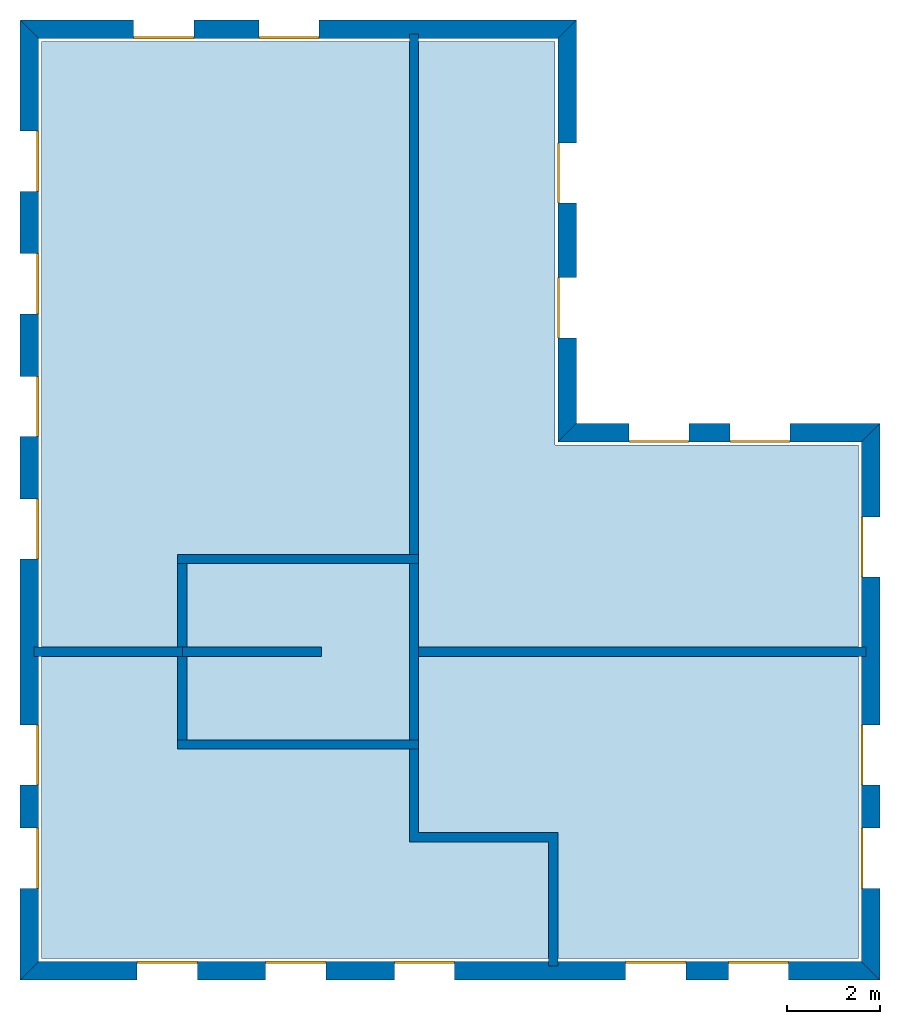
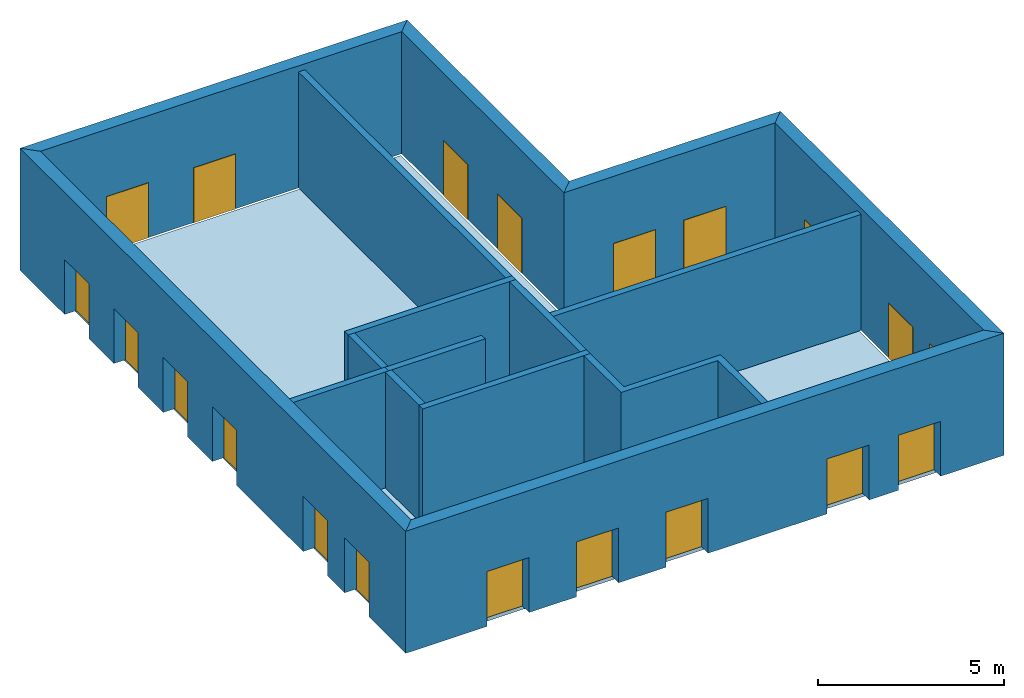
# One storey: 20 windows, 15 walls, 1 slab, 20 openings.
"""IFC4 building model written with IfcOpenShell, lengths in metres."""

from ifc_helpers import new_model, si_unit, origin_with_axes, place, context, subcontext, project, spatial, line, indexed_curve, outline, extrude, element, fill, save


model = new_model("IFC4")

# Units and contexts
model_context = context("Model", 3, precision=1e-05, world=origin_with_axes())
body_context = subcontext(model_context, "Body", "Model", "MODEL_VIEW")
ifc_project = project(units=[si_unit("AREAUNIT", "SQUARE_METRE"), si_unit("VOLUMEUNIT", "CUBIC_METRE"), si_unit("LENGTHUNIT", "METRE")], contexts=[model_context])

# Site, building, storey
site = spatial("IfcSite", under=ifc_project)
building = spatial("IfcBuilding", under=site, Name="Building 2")
storey_placement = place(None, origin_with_axes())
storey = spatial("IfcBuildingStorey", under=building, at=storey_placement, Name="01 Storey")

# Slab
slab_placement = place(storey_placement, origin_with_axes())
element("IfcSlab", 1, at=slab_placement, inside=storey, Name="Slab", context=body_context, shape_type="SweptSolid", body=[
    extrude(outline(indexed_curve([(22.079464, -3.619175), (15.533354, -3.619175), (15.533354, 5.0882), (4.453354, 5.0882), (4.453354, -14.699175), (22.079464, -14.699175)], segments=[line(1, 2), line(2, 3), line(3, 4), line(4, 5), line(5, 6)])), origin_with_axes(), (0.0, 0.0, -1.0), 0.2),
])

# Walls
wall_1_placement = place(storey_placement, origin_with_axes())
element("IfcWall", 2, at=wall_1_placement, inside=storey, Name="Wall", context=body_context, shape_type="SweptSolid", body=[
    extrude(outline(indexed_curve([(7.593354, -7.978543), (4.293354, -7.978543), (4.293354, -8.178543), (7.593354, -8.178543)], segments=[line(1, 2), line(2, 3), line(3, 4)])), origin_with_axes(), (0.0, 0.0, 1.0), 3.8),
])
wall_2_placement = place(storey_placement, origin_with_axes())
element("IfcWall", 3, at=wall_2_placement, inside=storey, Name="Wall", context=body_context, shape_type="SweptSolid", body=[
    extrude(outline(indexed_curve([(12.593354, 5.2482), (12.393354, 5.2482), (12.393354, -6.178543), (12.593354, -6.178543)], segments=[line(1, 2), line(2, 3), line(3, 4)])), origin_with_axes(), (0.0, 0.0, 1.0), 3.8),
])
wall_3_placement = place(storey_placement, origin_with_axes())
element("IfcWall", 4, at=wall_3_placement, inside=storey, Name="Wall", context=body_context, shape_type="SweptSolid", body=[
    extrude(outline(indexed_curve([(22.239464, -7.978543), (12.393354, -7.978543), (12.393354, -8.178543), (22.239464, -8.178543)], segments=[line(1, 2), line(2, 3), line(3, 4)])), origin_with_axes(), (0.0, 0.0, 1.0), 3.8),
])
wall_4_placement = place(storey_placement, origin_with_axes())
element("IfcWall", 5, at=wall_4_placement, inside=storey, Name="Wall", context=body_context, shape_type="SweptSolid", body=[
    extrude(outline(indexed_curve([(15.593354, -11.978543), (12.593354, -11.978543), (12.593354, -9.978543), (12.393354, -9.978543), (12.393354, -12.178543), (15.393354, -12.178543), (15.393354, -14.859175), (15.593354, -14.859175)], segments=[line(1, 2), line(2, 3), line(3, 4), line(4, 5), line(5, 6), line(6, 7), line(7, 8)])), origin_with_axes(), (0.0, 0.0, 1.0), 3.8),
])

# Wall, openings, windows
wall_5_placement = place(storey_placement, origin_with_axes())
wall_5 = element("IfcWall", 6, at=wall_5_placement, inside=storey, Name="Facade", context=body_context, shape_type="SweptSolid", body=[
    extrude(outline(indexed_curve([(22.139464, -3.559175), (15.593354, -3.559175), (15.993354, -3.159175), (22.539464, -3.159175)], segments=[line(1, 2), line(2, 3), line(3, 4)])), origin_with_axes(), (0.0, 0.0, 1.0), 4.0),
])
opening_1_placement = place(wall_5_placement, origin_with_axes())
opening_1 = element("IfcOpeningElement", 7, at=opening_1_placement, cuts=wall_5, Name="Opening", context=body_context, shape_type="SweptSolid", body=[
    extrude(outline(indexed_curve([(20.6074273333333, -3.119175), (20.6074273333333, -3.619175), (19.3074273333333, -3.619175), (19.3074273333333, -3.119175)], segments=[line(1, 2), line(2, 3), line(3, 4)])), origin_with_axes(), (0.0, 0.0, 1.0), 1.8),
])
opening_2_placement = place(wall_5_placement, origin_with_axes())
opening_2 = element("IfcOpeningElement", 8, at=opening_2_placement, cuts=wall_5, Name="Opening", context=body_context, shape_type="SweptSolid", body=[
    extrude(outline(indexed_curve([(18.4253906666667, -3.119175), (18.4253906666667, -3.619175), (17.1253906666667, -3.619175), (17.1253906666667, -3.119175)], segments=[line(1, 2), line(2, 3), line(3, 4)])), origin_with_axes(), (0.0, 0.0, 1.0), 1.8),
])
window_1_placement = place(storey_placement, origin_with_axes())
window_1 = element("IfcWindow", 9, at=window_1_placement, inside=storey, Name="Window", PredefinedType="WINDOW", context=body_context, shape_type="SweptSolid", body=[
    extrude(outline(indexed_curve([(20.6074273333333, -3.519175), (20.6074273333333, -3.569175), (19.3074273333333, -3.569175), (19.3074273333333, -3.519175)], segments=[line(1, 2), line(2, 3), line(3, 4)])), origin_with_axes(), (0.0, 0.0, 1.0), 1.8),
])
fill(opening_1, window_1)
window_2_placement = place(storey_placement, origin_with_axes())
window_2 = element("IfcWindow", 10, at=window_2_placement, inside=storey, Name="Window", PredefinedType="WINDOW", context=body_context, shape_type="SweptSolid", body=[
    extrude(outline(indexed_curve([(18.4253906666667, -3.519175), (18.4253906666667, -3.569175), (17.1253906666667, -3.569175), (17.1253906666667, -3.519175)], segments=[line(1, 2), line(2, 3), line(3, 4)])), origin_with_axes(), (0.0, 0.0, 1.0), 1.8),
])
fill(opening_2, window_2)

wall_6_placement = place(storey_placement, origin_with_axes())
wall_6 = element("IfcWall", 11, at=wall_6_placement, inside=storey, Name="Facade", context=body_context, shape_type="SweptSolid", body=[
    extrude(outline(indexed_curve([(15.593354, -3.559175), (15.593354, 5.1482), (15.993354, 5.5482), (15.993354, -3.159175)], segments=[line(1, 2), line(2, 3), line(3, 4)])), origin_with_axes(), (0.0, 0.0, 1.0), 4.0),
])
opening_3_placement = place(wall_6_placement, origin_with_axes())
opening_3 = element("IfcOpeningElement", 12, at=opening_3_placement, cuts=wall_6, Name="Opening", context=body_context, shape_type="SweptSolid", body=[
    extrude(outline(indexed_curve([(16.033354, -1.30671666666667), (15.533354, -1.30671666666667), (15.533354, -0.00671666666666659), (16.033354, -0.00671666666666659)], segments=[line(1, 2), line(2, 3), line(3, 4)])), origin_with_axes(), (0.0, 0.0, 1.0), 1.8),
])
opening_4_placement = place(wall_6_placement, origin_with_axes())
opening_4 = element("IfcOpeningElement", 13, at=opening_4_placement, cuts=wall_6, Name="Opening", context=body_context, shape_type="SweptSolid", body=[
    extrude(outline(indexed_curve([(16.033354, 1.59574166666667), (15.533354, 1.59574166666667), (15.533354, 2.89574166666667), (16.033354, 2.89574166666667)], segments=[line(1, 2), line(2, 3), line(3, 4)])), origin_with_axes(), (0.0, 0.0, 1.0), 1.8),
])
window_3_placement = place(storey_placement, origin_with_axes())
window_3 = element("IfcWindow", 14, at=window_3_placement, inside=storey, Name="Window", PredefinedType="WINDOW", context=body_context, shape_type="SweptSolid", body=[
    extrude(outline(indexed_curve([(15.633354, -1.30671666666667), (15.583354, -1.30671666666667), (15.583354, -0.00671666666666659), (15.633354, -0.00671666666666659)], segments=[line(1, 2), line(2, 3), line(3, 4)])), origin_with_axes(), (0.0, 0.0, 1.0), 1.8),
])
fill(opening_3, window_3)
window_4_placement = place(storey_placement, origin_with_axes())
window_4 = element("IfcWindow", 15, at=window_4_placement, inside=storey, Name="Window", PredefinedType="WINDOW", context=body_context, shape_type="SweptSolid", body=[
    extrude(outline(indexed_curve([(15.633354, 1.59574166666667), (15.583354, 1.59574166666667), (15.583354, 2.89574166666667), (15.633354, 2.89574166666667)], segments=[line(1, 2), line(2, 3), line(3, 4)])), origin_with_axes(), (0.0, 0.0, 1.0), 1.8),
])
fill(opening_4, window_4)

wall_7_placement = place(storey_placement, origin_with_axes())
wall_7 = element("IfcWall", 16, at=wall_7_placement, inside=storey, Name="Facade", context=body_context, shape_type="SweptSolid", body=[
    extrude(outline(indexed_curve([(15.593354, 5.1482), (4.393354, 5.1482), (3.993354, 5.5482), (15.993354, 5.5482)], segments=[line(1, 2), line(2, 3), line(3, 4)])), origin_with_axes(), (0.0, 0.0, 1.0), 4.0),
])
opening_5_placement = place(wall_7_placement, origin_with_axes())
opening_5 = element("IfcOpeningElement", 17, at=opening_5_placement, cuts=wall_7, Name="Opening", context=body_context, shape_type="SweptSolid", body=[
    extrude(outline(indexed_curve([(10.443354, 5.5882), (10.443354, 5.0882), (9.143354, 5.0882), (9.143354, 5.5882)], segments=[line(1, 2), line(2, 3), line(3, 4)])), origin_with_axes(), (0.0, 0.0, 1.0), 1.8),
])
opening_6_placement = place(wall_7_placement, origin_with_axes())
opening_6 = element("IfcOpeningElement", 18, at=opening_6_placement, cuts=wall_7, Name="Opening", context=body_context, shape_type="SweptSolid", body=[
    extrude(outline(indexed_curve([(7.743354, 5.5882), (7.743354, 5.0882), (6.443354, 5.0882), (6.443354, 5.5882)], segments=[line(1, 2), line(2, 3), line(3, 4)])), origin_with_axes(), (0.0, 0.0, 1.0), 1.8),
])
window_5_placement = place(storey_placement, origin_with_axes())
window_5 = element("IfcWindow", 19, at=window_5_placement, inside=storey, Name="Window", PredefinedType="WINDOW", context=body_context, shape_type="SweptSolid", body=[
    extrude(outline(indexed_curve([(10.443354, 5.1882), (10.443354, 5.1382), (9.143354, 5.1382), (9.143354, 5.1882)], segments=[line(1, 2), line(2, 3), line(3, 4)])), origin_with_axes(), (0.0, 0.0, 1.0), 1.8),
])
fill(opening_5, window_5)
window_6_placement = place(storey_placement, origin_with_axes())
window_6 = element("IfcWindow", 20, at=window_6_placement, inside=storey, Name="Window", PredefinedType="WINDOW", context=body_context, shape_type="SweptSolid", body=[
    extrude(outline(indexed_curve([(7.743354, 5.1882), (7.743354, 5.1382), (6.443354, 5.1382), (6.443354, 5.1882)], segments=[line(1, 2), line(2, 3), line(3, 4)])), origin_with_axes(), (0.0, 0.0, 1.0), 1.8),
])
fill(opening_6, window_6)

wall_8_placement = place(storey_placement, origin_with_axes())
wall_8 = element("IfcWall", 21, at=wall_8_placement, inside=storey, Name="Facade", context=body_context, shape_type="SweptSolid", body=[
    extrude(outline(indexed_curve([(4.393354, 5.1482), (4.393354, -14.759175), (3.993354, -15.159175), (3.993354, 5.5482)], segments=[line(1, 2), line(2, 3), line(3, 4)])), origin_with_axes(), (0.0, 0.0, 1.0), 4.0),
])
opening_7_placement = place(wall_8_placement, origin_with_axes())
opening_7 = element("IfcOpeningElement", 22, at=opening_7_placement, cuts=wall_8, Name="Opening", context=body_context, shape_type="SweptSolid", body=[
    extrude(outline(indexed_curve([(3.953354, 3.1528514), (4.453354, 3.1528514), (4.453354, 1.8528514), (3.953354, 1.8528514)], segments=[line(1, 2), line(2, 3), line(3, 4)])), origin_with_axes(), (0.0, 0.0, 1.0), 1.8),
])
opening_8_placement = place(wall_8_placement, origin_with_axes())
opening_8 = element("IfcOpeningElement", 23, at=opening_8_placement, cuts=wall_8, Name="Opening", context=body_context, shape_type="SweptSolid", body=[
    extrude(outline(indexed_curve([(3.953354, 0.507502800000001), (4.453354, 0.507502800000001), (4.453354, -0.792497199999999), (3.953354, -0.792497199999999)], segments=[line(1, 2), line(2, 3), line(3, 4)])), origin_with_axes(), (0.0, 0.0, 1.0), 1.8),
])
opening_9_placement = place(wall_8_placement, origin_with_axes())
opening_9 = element("IfcOpeningElement", 24, at=opening_9_placement, cuts=wall_8, Name="Opening", context=body_context, shape_type="SweptSolid", body=[
    extrude(outline(indexed_curve([(3.953354, -2.1378458), (4.453354, -2.1378458), (4.453354, -3.4378458), (3.953354, -3.4378458)], segments=[line(1, 2), line(2, 3), line(3, 4)])), origin_with_axes(), (0.0, 0.0, 1.0), 1.8),
])
opening_10_placement = place(wall_8_placement, origin_with_axes())
opening_10 = element("IfcOpeningElement", 25, at=opening_10_placement, cuts=wall_8, Name="Opening", context=body_context, shape_type="SweptSolid", body=[
    extrude(outline(indexed_curve([(3.953354, -4.7831944), (4.453354, -4.7831944), (4.453354, -6.0831944), (3.953354, -6.0831944)], segments=[line(1, 2), line(2, 3), line(3, 4)])), origin_with_axes(), (0.0, 0.0, 1.0), 1.8),
])
opening_11_placement = place(wall_8_placement, origin_with_axes())
opening_11 = element("IfcOpeningElement", 26, at=opening_11_placement, cuts=wall_8, Name="Opening", context=body_context, shape_type="SweptSolid", body=[
    extrude(outline(indexed_curve([(3.953354, -9.65542033333333), (4.453354, -9.65542033333333), (4.453354, -10.9554203333333), (3.953354, -10.9554203333333)], segments=[line(1, 2), line(2, 3), line(3, 4)])), origin_with_axes(), (0.0, 0.0, 1.0), 1.8),
])
opening_12_placement = place(wall_8_placement, origin_with_axes())
opening_12 = element("IfcOpeningElement", 27, at=opening_12_placement, cuts=wall_8, Name="Opening", context=body_context, shape_type="SweptSolid", body=[
    extrude(outline(indexed_curve([(3.953354, -11.8822976666667), (4.453354, -11.8822976666667), (4.453354, -13.1822976666667), (3.953354, -13.1822976666667)], segments=[line(1, 2), line(2, 3), line(3, 4)])), origin_with_axes(), (0.0, 0.0, 1.0), 1.8),
])
window_7_placement = place(storey_placement, origin_with_axes())
window_7 = element("IfcWindow", 28, at=window_7_placement, inside=storey, Name="Window", PredefinedType="WINDOW", context=body_context, shape_type="SweptSolid", body=[
    extrude(outline(indexed_curve([(4.353354, 3.1528514), (4.403354, 3.1528514), (4.403354, 1.8528514), (4.353354, 1.8528514)], segments=[line(1, 2), line(2, 3), line(3, 4)])), origin_with_axes(), (0.0, 0.0, 1.0), 1.8),
])
fill(opening_7, window_7)
window_8_placement = place(storey_placement, origin_with_axes())
window_8 = element("IfcWindow", 29, at=window_8_placement, inside=storey, Name="Window", PredefinedType="WINDOW", context=body_context, shape_type="SweptSolid", body=[
    extrude(outline(indexed_curve([(4.353354, 0.507502800000001), (4.403354, 0.507502800000001), (4.403354, -0.792497199999999), (4.353354, -0.792497199999999)], segments=[line(1, 2), line(2, 3), line(3, 4)])), origin_with_axes(), (0.0, 0.0, 1.0), 1.8),
])
fill(opening_8, window_8)
window_9_placement = place(storey_placement, origin_with_axes())
window_9 = element("IfcWindow", 30, at=window_9_placement, inside=storey, Name="Window", PredefinedType="WINDOW", context=body_context, shape_type="SweptSolid", body=[
    extrude(outline(indexed_curve([(4.353354, -2.1378458), (4.403354, -2.1378458), (4.403354, -3.4378458), (4.353354, -3.4378458)], segments=[line(1, 2), line(2, 3), line(3, 4)])), origin_with_axes(), (0.0, 0.0, 1.0), 1.8),
])
fill(opening_9, window_9)
window_10_placement = place(storey_placement, origin_with_axes())
window_10 = element("IfcWindow", 31, at=window_10_placement, inside=storey, Name="Window", PredefinedType="WINDOW", context=body_context, shape_type="SweptSolid", body=[
    extrude(outline(indexed_curve([(4.353354, -4.7831944), (4.403354, -4.7831944), (4.403354, -6.0831944), (4.353354, -6.0831944)], segments=[line(1, 2), line(2, 3), line(3, 4)])), origin_with_axes(), (0.0, 0.0, 1.0), 1.8),
])
fill(opening_10, window_10)
window_11_placement = place(storey_placement, origin_with_axes())
window_11 = element("IfcWindow", 32, at=window_11_placement, inside=storey, Name="Window", PredefinedType="WINDOW", context=body_context, shape_type="SweptSolid", body=[
    extrude(outline(indexed_curve([(4.353354, -9.65542033333333), (4.403354, -9.65542033333333), (4.403354, -10.9554203333333), (4.353354, -10.9554203333333)], segments=[line(1, 2), line(2, 3), line(3, 4)])), origin_with_axes(), (0.0, 0.0, 1.0), 1.8),
])
fill(opening_11, window_11)
window_12_placement = place(storey_placement, origin_with_axes())
window_12 = element("IfcWindow", 33, at=window_12_placement, inside=storey, Name="Window", PredefinedType="WINDOW", context=body_context, shape_type="SweptSolid", body=[
    extrude(outline(indexed_curve([(4.353354, -11.8822976666667), (4.403354, -11.8822976666667), (4.403354, -13.1822976666667), (4.353354, -13.1822976666667)], segments=[line(1, 2), line(2, 3), line(3, 4)])), origin_with_axes(), (0.0, 0.0, 1.0), 1.8),
])
fill(opening_12, window_12)

wall_9_placement = place(storey_placement, origin_with_axes())
wall_9 = element("IfcWall", 34, at=wall_9_placement, inside=storey, Name="Facade", context=body_context, shape_type="SweptSolid", body=[
    extrude(outline(indexed_curve([(4.393354, -14.759175), (22.139464, -14.759175), (22.539464, -15.159175), (3.993354, -15.159175)], segments=[line(1, 2), line(2, 3), line(3, 4)])), origin_with_axes(), (0.0, 0.0, 1.0), 4.0),
])
opening_13_placement = place(wall_9_placement, origin_with_axes())
opening_13 = element("IfcOpeningElement", 35, at=opening_13_placement, cuts=wall_9, Name="Opening", context=body_context, shape_type="SweptSolid", body=[
    extrude(outline(indexed_curve([(17.058724, -15.199175), (17.058724, -14.699175), (18.358724, -14.699175), (18.358724, -15.199175)], segments=[line(1, 2), line(2, 3), line(3, 4)])), origin_with_axes(), (0.0, 0.0, 1.0), 1.8),
])
opening_14_placement = place(wall_9_placement, origin_with_axes())
opening_14 = element("IfcOpeningElement", 36, at=opening_14_placement, cuts=wall_9, Name="Opening", context=body_context, shape_type="SweptSolid", body=[
    extrude(outline(indexed_curve([(19.274094, -15.199175), (19.274094, -14.699175), (20.574094, -14.699175), (20.574094, -15.199175)], segments=[line(1, 2), line(2, 3), line(3, 4)])), origin_with_axes(), (0.0, 0.0, 1.0), 1.8),
])
opening_15_placement = place(wall_9_placement, origin_with_axes())
opening_15 = element("IfcOpeningElement", 37, at=opening_15_placement, cuts=wall_9, Name="Opening", context=body_context, shape_type="SweptSolid", body=[
    extrude(outline(indexed_curve([(6.518354, -15.199175), (6.518354, -14.699175), (7.818354, -14.699175), (7.818354, -15.199175)], segments=[line(1, 2), line(2, 3), line(3, 4)])), origin_with_axes(), (0.0, 0.0, 1.0), 1.8),
])
opening_16_placement = place(wall_9_placement, origin_with_axes())
opening_16 = element("IfcOpeningElement", 38, at=opening_16_placement, cuts=wall_9, Name="Opening", context=body_context, shape_type="SweptSolid", body=[
    extrude(outline(indexed_curve([(9.293354, -15.199175), (9.293354, -14.699175), (10.593354, -14.699175), (10.593354, -15.199175)], segments=[line(1, 2), line(2, 3), line(3, 4)])), origin_with_axes(), (0.0, 0.0, 1.0), 1.8),
])
opening_17_placement = place(wall_9_placement, origin_with_axes())
opening_17 = element("IfcOpeningElement", 39, at=opening_17_placement, cuts=wall_9, Name="Opening", context=body_context, shape_type="SweptSolid", body=[
    extrude(outline(indexed_curve([(12.068354, -15.199175), (12.068354, -14.699175), (13.368354, -14.699175), (13.368354, -15.199175)], segments=[line(1, 2), line(2, 3), line(3, 4)])), origin_with_axes(), (0.0, 0.0, 1.0), 1.8),
])
window_13_placement = place(storey_placement, origin_with_axes())
window_13 = element("IfcWindow", 40, at=window_13_placement, inside=storey, Name="Window", PredefinedType="WINDOW", context=body_context, shape_type="SweptSolid", body=[
    extrude(outline(indexed_curve([(17.058724, -14.799175), (17.058724, -14.749175), (18.358724, -14.749175), (18.358724, -14.799175)], segments=[line(1, 2), line(2, 3), line(3, 4)])), origin_with_axes(), (0.0, 0.0, 1.0), 1.8),
])
fill(opening_13, window_13)
window_14_placement = place(storey_placement, origin_with_axes())
window_14 = element("IfcWindow", 41, at=window_14_placement, inside=storey, Name="Window", PredefinedType="WINDOW", context=body_context, shape_type="SweptSolid", body=[
    extrude(outline(indexed_curve([(19.274094, -14.799175), (19.274094, -14.749175), (20.574094, -14.749175), (20.574094, -14.799175)], segments=[line(1, 2), line(2, 3), line(3, 4)])), origin_with_axes(), (0.0, 0.0, 1.0), 1.8),
])
fill(opening_14, window_14)
window_15_placement = place(storey_placement, origin_with_axes())
window_15 = element("IfcWindow", 42, at=window_15_placement, inside=storey, Name="Window", PredefinedType="WINDOW", context=body_context, shape_type="SweptSolid", body=[
    extrude(outline(indexed_curve([(6.518354, -14.799175), (6.518354, -14.749175), (7.818354, -14.749175), (7.818354, -14.799175)], segments=[line(1, 2), line(2, 3), line(3, 4)])), origin_with_axes(), (0.0, 0.0, 1.0), 1.8),
])
fill(opening_15, window_15)
window_16_placement = place(storey_placement, origin_with_axes())
window_16 = element("IfcWindow", 43, at=window_16_placement, inside=storey, Name="Window", PredefinedType="WINDOW", context=body_context, shape_type="SweptSolid", body=[
    extrude(outline(indexed_curve([(9.293354, -14.799175), (9.293354, -14.749175), (10.593354, -14.749175), (10.593354, -14.799175)], segments=[line(1, 2), line(2, 3), line(3, 4)])), origin_with_axes(), (0.0, 0.0, 1.0), 1.8),
])
fill(opening_16, window_16)
window_17_placement = place(storey_placement, origin_with_axes())
window_17 = element("IfcWindow", 44, at=window_17_placement, inside=storey, Name="Window", PredefinedType="WINDOW", context=body_context, shape_type="SweptSolid", body=[
    extrude(outline(indexed_curve([(12.068354, -14.799175), (12.068354, -14.749175), (13.368354, -14.749175), (13.368354, -14.799175)], segments=[line(1, 2), line(2, 3), line(3, 4)])), origin_with_axes(), (0.0, 0.0, 1.0), 1.8),
])
fill(opening_17, window_17)

wall_10_placement = place(storey_placement, origin_with_axes())
wall_10 = element("IfcWall", 45, at=wall_10_placement, inside=storey, Name="Facade", context=body_context, shape_type="SweptSolid", body=[
    extrude(outline(indexed_curve([(22.139464, -14.759175), (22.139464, -3.559175), (22.539464, -3.159175), (22.539464, -15.159175)], segments=[line(1, 2), line(2, 3), line(3, 4)])), origin_with_axes(), (0.0, 0.0, 1.0), 4.0),
])
opening_18_placement = place(wall_10_placement, origin_with_axes())
opening_18 = element("IfcOpeningElement", 46, at=opening_18_placement, cuts=wall_10, Name="Opening", context=body_context, shape_type="SweptSolid", body=[
    extrude(outline(indexed_curve([(22.579464, -6.468859), (22.079464, -6.468859), (22.079464, -5.168859), (22.579464, -5.168859)], segments=[line(1, 2), line(2, 3), line(3, 4)])), origin_with_axes(), (0.0, 0.0, 1.0), 1.8),
])
opening_19_placement = place(wall_10_placement, origin_with_axes())
opening_19 = element("IfcOpeningElement", 47, at=opening_19_placement, cuts=wall_10, Name="Opening", context=body_context, shape_type="SweptSolid", body=[
    extrude(outline(indexed_curve([(22.579464, -13.1822976666667), (22.079464, -13.1822976666667), (22.079464, -11.8822976666667), (22.579464, -11.8822976666667)], segments=[line(1, 2), line(2, 3), line(3, 4)])), origin_with_axes(), (0.0, 0.0, 1.0), 1.8),
])
opening_20_placement = place(wall_10_placement, origin_with_axes())
opening_20 = element("IfcOpeningElement", 48, at=opening_20_placement, cuts=wall_10, Name="Opening", context=body_context, shape_type="SweptSolid", body=[
    extrude(outline(indexed_curve([(22.579464, -10.9554203333333), (22.079464, -10.9554203333333), (22.079464, -9.65542033333333), (22.579464, -9.65542033333333)], segments=[line(1, 2), line(2, 3), line(3, 4)])), origin_with_axes(), (0.0, 0.0, 1.0), 1.8),
])
window_18_placement = place(storey_placement, origin_with_axes())
window_18 = element("IfcWindow", 49, at=window_18_placement, inside=storey, Name="Window", PredefinedType="WINDOW", context=body_context, shape_type="SweptSolid", body=[
    extrude(outline(indexed_curve([(22.179464, -6.468859), (22.129464, -6.468859), (22.129464, -5.168859), (22.179464, -5.168859)], segments=[line(1, 2), line(2, 3), line(3, 4)])), origin_with_axes(), (0.0, 0.0, 1.0), 1.8),
])
fill(opening_18, window_18)
window_19_placement = place(storey_placement, origin_with_axes())
window_19 = element("IfcWindow", 50, at=window_19_placement, inside=storey, Name="Window", PredefinedType="WINDOW", context=body_context, shape_type="SweptSolid", body=[
    extrude(outline(indexed_curve([(22.179464, -13.1822976666667), (22.129464, -13.1822976666667), (22.129464, -11.8822976666667), (22.179464, -11.8822976666667)], segments=[line(1, 2), line(2, 3), line(3, 4)])), origin_with_axes(), (0.0, 0.0, 1.0), 1.8),
])
fill(opening_19, window_19)
window_20_placement = place(storey_placement, origin_with_axes())
window_20 = element("IfcWindow", 51, at=window_20_placement, inside=storey, Name="Window", PredefinedType="WINDOW", context=body_context, shape_type="SweptSolid", body=[
    extrude(outline(indexed_curve([(22.179464, -10.9554203333333), (22.129464, -10.9554203333333), (22.129464, -9.65542033333333), (22.179464, -9.65542033333333)], segments=[line(1, 2), line(2, 3), line(3, 4)])), origin_with_axes(), (0.0, 0.0, 1.0), 1.8),
])
fill(opening_20, window_20)

# Walls
wall_11_placement = place(storey_placement, origin_with_axes())
element("IfcWall", 52, at=wall_11_placement, inside=storey, Name="CoreWall", context=body_context, shape_type="SweptSolid", body=[
    extrude(outline(indexed_curve([(12.593354, -5.978543), (7.393354, -5.978543), (7.393354, -6.178543), (12.593354, -6.178543)], segments=[line(1, 2), line(2, 3), line(3, 4)])), origin_with_axes(), (0.0, 0.0, 1.0), 3.8),
])
wall_12_placement = place(storey_placement, origin_with_axes())
element("IfcWall", 53, at=wall_12_placement, inside=storey, Name="CoreWall", context=body_context, shape_type="SweptSolid", body=[
    extrude(outline(indexed_curve([(7.393354, -10.178543), (12.593354, -10.178543), (12.593354, -9.978543), (7.393354, -9.978543)], segments=[line(1, 2), line(2, 3), line(3, 4)])), origin_with_axes(), (0.0, 0.0, 1.0), 3.8),
])
wall_13_placement = place(storey_placement, origin_with_axes())
element("IfcWall", 54, at=wall_13_placement, inside=storey, Name="CoreWall", context=body_context, shape_type="SweptSolid", body=[
    extrude(outline(indexed_curve([(7.593354, -9.978543), (7.593354, -6.178543), (7.393354, -6.178543), (7.393354, -9.978543)], segments=[line(1, 2), line(2, 3), line(3, 4)])), origin_with_axes(), (0.0, 0.0, 1.0), 3.8),
])
wall_14_placement = place(storey_placement, origin_with_axes())
element("IfcWall", 55, at=wall_14_placement, inside=storey, Name="CoreWall", context=body_context, shape_type="SweptSolid", body=[
    extrude(outline(indexed_curve([(12.393354, -6.178543), (12.393354, -9.978543), (12.593354, -9.978543), (12.593354, -6.178543)], segments=[line(1, 2), line(2, 3), line(3, 4)])), origin_with_axes(), (0.0, 0.0, 1.0), 3.8),
])
wall_15_placement = place(storey_placement, origin_with_axes())
element("IfcWall", 56, at=wall_15_placement, inside=storey, Name="CoreWall", context=body_context, shape_type="SweptSolid", body=[
    extrude(outline(indexed_curve([(10.493354, -7.978543), (7.493354, -7.978543), (7.493354, -8.178543), (10.493354, -8.178543)], segments=[line(1, 2), line(2, 3), line(3, 4)])), origin_with_axes(), (0.0, 0.0, 1.0), 3.8),
])

save(model, "model.ifc")
